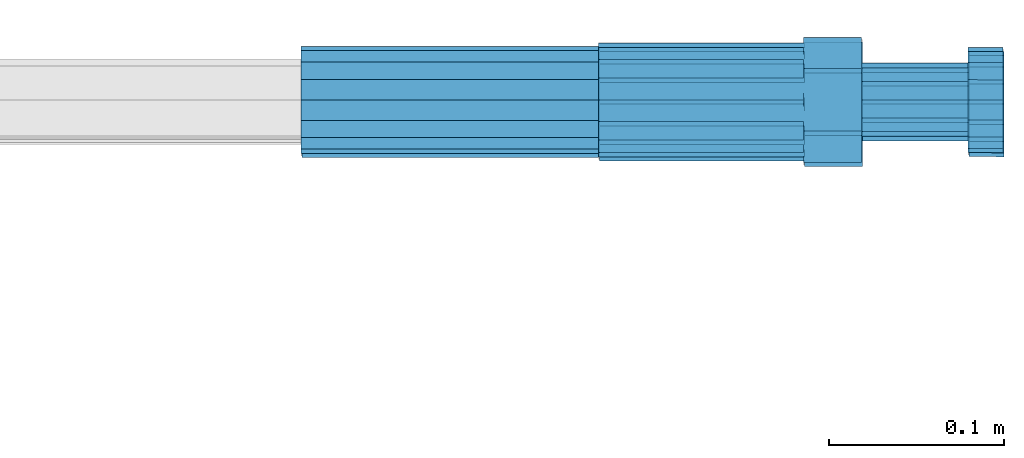
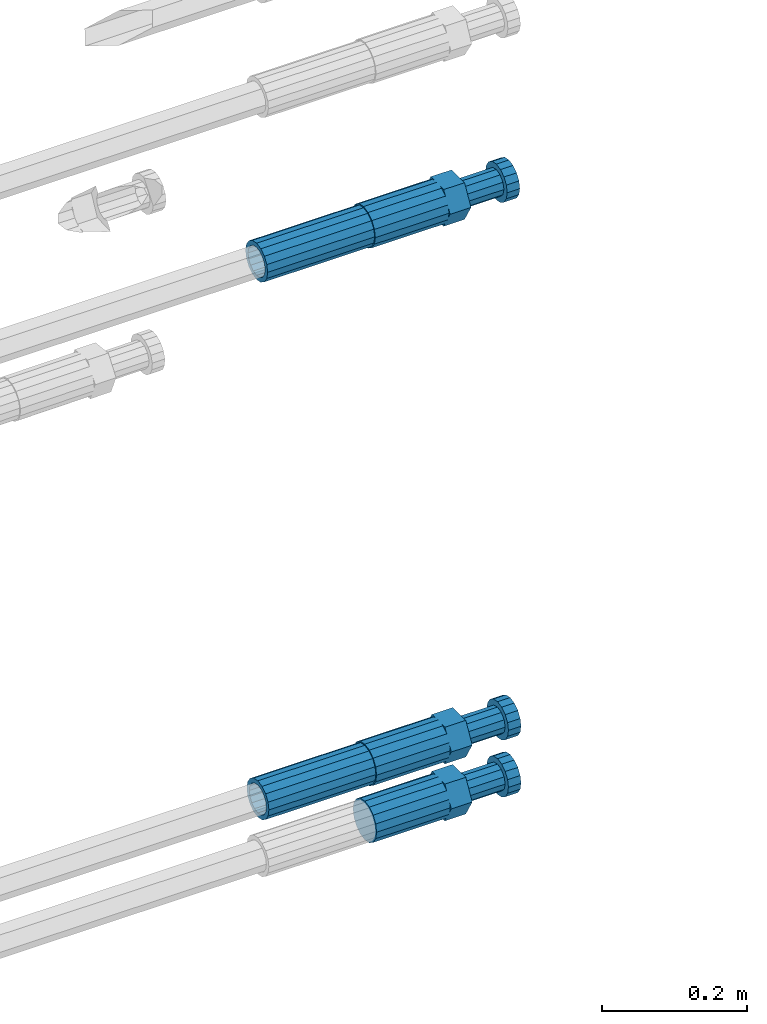
# One storey, part 113 of 177: 5 beams.
"""IFC2X3 building model written with IfcOpenShell, lengths in millimetres."""

from ifc_helpers import new_model, si_unit, frame, origin_with_axes, place, context, subcontext, project, spatial, faceted_brep, material, type_object, element, save


model = new_model("IFC2X3")

# Units and contexts
model_context_1 = context("Model", 3, precision=1e-05, world=origin_with_axes())
model_context_2 = context("Model", 3, precision=1e-05, world=origin_with_axes())
body_context = subcontext(model_context_2, "Body", "Model", "MODEL_VIEW")
ifc_project = project(units=[si_unit("LENGTHUNIT", "METRE", prefix="MILLI"), si_unit("AREAUNIT", "SQUARE_METRE"), si_unit("VOLUMEUNIT", "CUBIC_METRE"), si_unit("MASSUNIT", "GRAM", prefix="KILO"), si_unit("TIMEUNIT", "SECOND"), si_unit("PLANEANGLEUNIT", "RADIAN"), si_unit("SOLIDANGLEUNIT", "STERADIAN"), si_unit("THERMODYNAMICTEMPERATUREUNIT", "DEGREE_CELSIUS"), si_unit("LUMINOUSINTENSITYUNIT", "LUMEN")], contexts=[model_context_1])

# Site, building, storey
site_placement = place(None, origin_with_axes())
site = spatial("IfcSite", under=ifc_project, at=site_placement, CompositionType="ELEMENT")
building_placement = place(site_placement, origin_with_axes())
building = spatial("IfcBuilding", under=site, at=building_placement, Name="Undefined", CompositionType="ELEMENT")
storey_placement = place(building_placement, origin_with_axes())
storey = spatial("IfcBuildingStorey", under=building, at=storey_placement, Name="Undefined", CompositionType="ELEMENT", Elevation=0.0)

# Beams
ifc_material = material(Name="STEEL/S275")
beam_type_1 = type_object("IfcBeamType", PredefinedType="NOTDEFINED")
beam_1_placement = place(storey_placement, frame((2039349.52037948, 6206397.98588036, 18692.99680043), z_axis=(0.0, 0.0, -1.0), x_axis=(1.0, 0.0, 0.0)))
element("IfcBeam", 1, at=beam_1_placement, inside=storey, type_object=beam_type_1, material=ifc_material, Name="AG40N", context=body_context, shape_type="Brep", body=[
    faceted_brep([(0.0, -23.5000000001164, -9.31322574615479e-10), (0.0, -21.7111690140155, 8.99306066054851), (170.0, -21.7111690140155, 8.99306066054851), (170.0, -23.5, 0.0), (0.0, -16.6170093578839, 16.6170093575493), (170.0, -16.6170093578839, 16.6170093575493), (0.0, -8.99306066057943, 21.7111690137535), (170.0, -8.99306066057943, 21.7111690137535), (0.0, 1.16415321826935e-10, 23.5), (170.0, 0.0, 23.5), (0.0, 8.99306066057943, 21.7111690137535), (170.0, 8.99306066057943, 21.7111690137535), (0.0, 16.6170093578839, 16.6170093575493), (170.0, 16.6170093578839, 16.6170093575493), (0.0, 21.7111690140155, 8.99306066054851), (170.0, 21.7111690140155, 8.99306066054851), (0.0, 23.5000000001164, -9.31322574615479e-10), (170.0, 23.5, 0.0), (0.0, 21.7111690140155, -8.99306066054851), (170.0, 21.7111690140155, -8.99306066054851), (0.0, 16.6170093578839, -16.6170093575493), (170.0, 16.6170093578839, -16.6170093575493), (0.0, 8.99306066057943, -21.7111690137535), (170.0, 8.99306066057943, -21.7111690137535), (0.0, 1.16415321826935e-10, -23.5000000009313), (170.0, 0.0, -23.5), (0.0, -8.99306066057943, -21.7111690137535), (170.0, -8.99306066057943, -21.7111690137535), (0.0, -16.6170093578839, -16.6170093575493), (170.0, -16.6170093578839, -16.6170093575493), (0.0, -21.7111690140155, -8.99306066054851), (170.0, -21.7111690140155, -8.99306066054851), (0.0, -30.5, 0.0), (0.0, -28.1783257415937, -11.6718446873128), (170.0, -28.1783257415937, -11.6718446873128), (170.0, -30.5, 0.0), (0.0, -21.5667568261888, -21.5667568258941), (170.0, -21.5667568261888, -21.5667568258941), (0.0, -11.6718446871346, -28.1783257415518), (170.0, -11.6718446871346, -28.1783257415518), (0.0, 0.0, -30.5), (170.0, 0.0, -30.5), (0.0, 11.6718446871346, -28.1783257415518), (170.0, 11.6718446871346, -28.1783257415518), (0.0, 21.5667568261888, -21.5667568258941), (170.0, 21.5667568261888, -21.5667568258941), (0.0, 28.1783257415937, -11.6718446873128), (170.0, 28.1783257415937, -11.6718446873128), (0.0, 30.5, 0.0), (170.0, 30.5, 0.0), (0.0, 28.1783257415937, 11.6718446873128), (170.0, 28.1783257415937, 11.6718446873128), (0.0, 21.5667568261888, 21.5667568258941), (170.0, 21.5667568261888, 21.5667568258941), (0.0, 11.6718446871346, 28.1783257415518), (170.0, 11.6718446871346, 28.1783257415518), (0.0, 0.0, 30.5), (170.0, 0.0, 30.5), (0.0, -11.6718446871346, 28.1783257415518), (170.0, -11.6718446871346, 28.1783257415518), (0.0, -21.5667568261888, 21.5667568258941), (170.0, -21.5667568261888, 21.5667568258941), (0.0, -28.1783257415937, 11.6718446873128), (170.0, -28.1783257415937, 11.6718446873128)], [[[0, 1, 2, 3]], [[1, 4, 5, 2]], [[4, 6, 7, 5]], [[6, 8, 9, 7]], [[8, 10, 11, 9]], [[10, 12, 13, 11]], [[12, 14, 15, 13]], [[14, 16, 17, 15]], [[16, 18, 19, 17]], [[18, 20, 21, 19]], [[20, 22, 23, 21]], [[22, 24, 25, 23]], [[24, 26, 27, 25]], [[26, 28, 29, 27]], [[28, 30, 31, 29]], [[30, 0, 3, 31]], [[32, 33, 34, 35]], [[33, 36, 37, 34]], [[36, 38, 39, 37]], [[38, 40, 41, 39]], [[40, 42, 43, 41]], [[42, 44, 45, 43]], [[44, 46, 47, 45]], [[46, 48, 49, 47]], [[48, 50, 51, 49]], [[50, 52, 53, 51]], [[52, 54, 55, 53]], [[54, 56, 57, 55]], [[56, 58, 59, 57]], [[58, 60, 61, 59]], [[60, 62, 63, 61]], [[62, 32, 35, 63]], [[37, 39, 41, 43, 45, 47, 49, 51, 53, 55, 57, 59, 61, 63, 35, 34], [5, 7, 9, 11, 13, 15, 17, 19, 21, 23, 25, 27, 29, 31, 3, 2]], [[62, 60, 58, 56, 54, 52, 50, 48, 46, 44, 42, 40, 38, 36, 33, 32], [30, 28, 26, 24, 22, 20, 18, 16, 14, 12, 10, 8, 6, 4, 1, 0]]]),
])
beam_2_placement = place(storey_placement, frame((2039349.02037948, 6206400.48588035, 19594.9868004301), z_axis=(0.0, 0.0, -1.0), x_axis=(1.0, 0.0, 0.0)))
element("IfcBeam", 2, at=beam_2_placement, inside=storey, type_object=beam_type_1, material=ifc_material, Name="AG40N", context=body_context, shape_type="Brep", body=[
    faceted_brep([(0.0, -23.5000000001164, -9.31322574615479e-10), (0.0, -21.7111690140155, 8.99306066054851), (170.0, -21.7111690140155, 8.99306066054851), (170.0, -23.5, 0.0), (0.0, -16.6170093578839, 16.6170093575493), (170.0, -16.6170093578839, 16.6170093575493), (0.0, -8.99306066057943, 21.7111690137535), (170.0, -8.99306066057943, 21.7111690137535), (0.0, 1.16415321826935e-10, 23.5), (170.0, 0.0, 23.5), (0.0, 8.99306066057943, 21.7111690137535), (170.0, 8.99306066057943, 21.7111690137535), (0.0, 16.6170093578839, 16.6170093575493), (170.0, 16.6170093578839, 16.6170093575493), (0.0, 21.7111690140155, 8.99306066054851), (170.0, 21.7111690140155, 8.99306066054851), (0.0, 23.5000000001164, -9.31322574615479e-10), (170.0, 23.5, 0.0), (0.0, 21.7111690140155, -8.99306066054851), (170.0, 21.7111690140155, -8.99306066054851), (0.0, 16.6170093578839, -16.6170093575493), (170.0, 16.6170093578839, -16.6170093575493), (0.0, 8.99306066057943, -21.7111690137535), (170.0, 8.99306066057943, -21.7111690137535), (0.0, 1.16415321826935e-10, -23.5000000009313), (170.0, 0.0, -23.5), (0.0, -8.99306066057943, -21.7111690137535), (170.0, -8.99306066057943, -21.7111690137535), (0.0, -16.6170093578839, -16.6170093575493), (170.0, -16.6170093578839, -16.6170093575493), (0.0, -21.7111690140155, -8.99306066054851), (170.0, -21.7111690140155, -8.99306066054851), (0.0, -30.5, 0.0), (0.0, -28.1783257415937, -11.6718446873128), (170.0, -28.1783257415937, -11.6718446873128), (170.0, -30.5, 0.0), (0.0, -21.5667568261888, -21.5667568258941), (170.0, -21.5667568261888, -21.5667568258941), (0.0, -11.6718446871346, -28.1783257415518), (170.0, -11.6718446871346, -28.1783257415518), (0.0, 0.0, -30.5), (170.0, 0.0, -30.5), (0.0, 11.6718446871346, -28.1783257415518), (170.0, 11.6718446871346, -28.1783257415518), (0.0, 21.5667568261888, -21.5667568258941), (170.0, 21.5667568261888, -21.5667568258941), (0.0, 28.1783257415937, -11.6718446873128), (170.0, 28.1783257415937, -11.6718446873128), (0.0, 30.5, 0.0), (170.0, 30.5, 0.0), (0.0, 28.1783257415937, 11.6718446873128), (170.0, 28.1783257415937, 11.6718446873128), (0.0, 21.5667568261888, 21.5667568258941), (170.0, 21.5667568261888, 21.5667568258941), (0.0, 11.6718446871346, 28.1783257415518), (170.0, 11.6718446871346, 28.1783257415518), (0.0, 0.0, 30.5), (170.0, 0.0, 30.5), (0.0, -11.6718446871346, 28.1783257415518), (170.0, -11.6718446871346, 28.1783257415518), (0.0, -21.5667568261888, 21.5667568258941), (170.0, -21.5667568261888, 21.5667568258941), (0.0, -28.1783257415937, 11.6718446873128), (170.0, -28.1783257415937, 11.6718446873128)], [[[0, 1, 2, 3]], [[1, 4, 5, 2]], [[4, 6, 7, 5]], [[6, 8, 9, 7]], [[8, 10, 11, 9]], [[10, 12, 13, 11]], [[12, 14, 15, 13]], [[14, 16, 17, 15]], [[16, 18, 19, 17]], [[18, 20, 21, 19]], [[20, 22, 23, 21]], [[22, 24, 25, 23]], [[24, 26, 27, 25]], [[26, 28, 29, 27]], [[28, 30, 31, 29]], [[30, 0, 3, 31]], [[32, 33, 34, 35]], [[33, 36, 37, 34]], [[36, 38, 39, 37]], [[38, 40, 41, 39]], [[40, 42, 43, 41]], [[42, 44, 45, 43]], [[44, 46, 47, 45]], [[46, 48, 49, 47]], [[48, 50, 51, 49]], [[50, 52, 53, 51]], [[52, 54, 55, 53]], [[54, 56, 57, 55]], [[56, 58, 59, 57]], [[58, 60, 61, 59]], [[60, 62, 63, 61]], [[62, 32, 35, 63]], [[37, 39, 41, 43, 45, 47, 49, 51, 53, 55, 57, 59, 61, 63, 35, 34], [5, 7, 9, 11, 13, 15, 17, 19, 21, 23, 25, 27, 29, 31, 3, 2]], [[62, 60, 58, 56, 54, 52, 50, 48, 46, 44, 42, 40, 38, 36, 33, 32], [30, 28, 26, 24, 22, 20, 18, 16, 14, 12, 10, 8, 6, 4, 1, 0]]]),
])
beam_type_2 = type_object("IfcBeamType", Name="ROD65", PredefinedType="NOTDEFINED")
beam_3_placement = place(storey_placement, frame((2039519.52037948, 6206397.98588036, 18597.2968004168), z_axis=(0.0, 0.0, -1.0), x_axis=(1.0, 0.0, 0.0)))
element("IfcBeam", 3, at=beam_3_placement, inside=storey, type_object=beam_type_2, material=ifc_material, Name="AGB40", ObjectType="ROD65", context=body_context, shape_type="Brep", body=[
    faceted_brep([(117.0, 8.17543110251427, 30.873805644922), (117.0, 17.8250000001863, 30.873805644922), (117.0, 22.0056958701462, 23.6326279877685), (117.0, 12.4372115517035, 30.0260848065373), (117.0, -17.8250000001863, 30.873805644922), (150.200000000186, -17.8250000001863, 30.873805644922), (150.200000000186, 17.8250000001863, 30.873805644922), (117.0, -8.17543110251427, 30.873805644922), (117.0, -12.4372115517035, 30.0260848065373), (117.0, -22.0056958701462, 23.6326279877685), (117.0, -35.6500000003725, 0.0), (150.200000000186, -35.6500000003725, 0.0), (117.0, -30.8443150008097, 8.32369058486074), (117.0, -32.5, 0.0), (117.0, -30.8443150008097, -8.32369058462791), (117.0, -17.8250000001863, -30.873805644922), (150.200000000186, -17.8250000001863, -30.873805644922), (117.0, -22.0056958701462, -23.6326279877685), (117.0, -12.4372115517035, -30.0260848065373), (117.0, -8.17543110251427, -30.873805644922), (117.0, 17.8250000001863, -30.873805644922), (150.200000000186, 17.8250000001863, -30.873805644922), (117.0, 8.17543110251427, -30.873805644922), (117.0, 22.0056958701462, -23.6326279877685), (117.0, 12.4372115517035, -30.0260848065373), (117.0, 35.6500000003725, 0.0), (150.200000000186, 35.6500000003725, 0.0), (117.0, 30.8443150008097, -8.32369058486074), (117.0, 30.8443150008097, 8.32369058462791), (117.0, 32.5, 0.0), (0.0, -22.9809703892097, 22.9809703885621), (0.0, -30.0260848058388, 12.4372115518636), (117.0, -30.0260848067701, 12.4372115519363), (117.0, -22.9809703882784, 22.9809703885112), (-2.3283064365387e-10, 22.9809703892097, -22.9809703885639), (-4.65661287307739e-10, 30.0260848077014, -12.4372115518672), (117.0, 30.0260848067701, -12.4372115519363), (117.0, 22.9809703882784, -22.9809703885112), (-2.3283064365387e-10, -30.0260848067701, -12.4372115518672), (-2.3283064365387e-10, -22.9809703892097, -22.9809703885621), (117.0, -22.9809703882784, -22.9809703885112), (117.0, -30.0260848067701, -12.4372115519363), (-2.3283064365387e-10, -12.4372115507722, 30.0260848066137), (-2.3283064365387e-10, 9.31322574615479e-10, 32.4999999999982), (-2.3283064365387e-10, 12.4372115526348, 30.0260848066137), (0.0, 22.9809703892097, 22.9809703885621), (-2.3283064365387e-10, 30.0260848077014, 12.4372115518636), (-2.3283064365387e-10, 32.5, 0.0), (-2.3283064365387e-10, 12.4372115526348, -30.0260848066173), (-2.3283064365387e-10, 9.31322574615479e-10, -32.5), (-2.3283064365387e-10, -12.4372115517035, -30.0260848066173), (-4.65661287307739e-10, -32.4999999990687, -1.81898940354586e-12), (117.0, 22.9809703882784, 22.9809703885112), (117.0, 30.0260848067701, 12.4372115519363), (117.0, 0.0, -32.5), (117.0, 0.0, 32.5), (150.200000000186, 10.5, -18.1865334794857), (150.200000000186, 0.0, -21.0), (150.200000000186, -10.5, -18.1865334794857), (150.200000000186, -18.18653347902, -10.5), (150.200000000186, -21.0, 0.0), (150.200000000186, -18.18653347902, 10.5), (150.200000000186, -10.5, 18.1865334794857), (150.200000000186, 0.0, 21.0), (150.200000000186, 10.5, 18.1865334794857), (150.200000000186, 18.18653347902, 10.5), (150.200000000186, 21.0, 0.0), (150.200000000186, 18.18653347902, -10.5), (210.980000000447, -18.18653347902, 10.5), (210.980000000447, -21.0, 0.0), (210.980000000447, -10.5, 18.1865334794857), (210.980000000447, 0.0, 21.0), (210.980000000447, 10.5, 18.1865334794857), (210.980000000447, 18.18653347902, 10.5), (210.980000000447, 21.0, 0.0), (210.980000000447, 18.18653347902, -10.5), (210.980000000447, 10.5, -18.1865334794857), (210.980000000447, 0.0, -21.0), (210.980000000447, -10.5, -18.1865334794857), (210.980000000447, -18.18653347902, -10.5), (211.001368442696, -27.7269937992096, -11.491116326768), (211.003082550167, -21.2238094303757, -21.223815418547), (231.002518367059, -21.2131944671273, -21.2132004550658), (231.000804259587, -27.7163788359612, -11.4805013632867), (211.001368440451, -11.4911085031927, -27.7269970395137), (231.000804257343, -11.4804935399443, -27.7163820760325), (210.996487071217, -0.0106065049767494, -30.0106107392348), (230.995922888109, 8.45827162265778e-06, -29.9999957757536), (210.989181586672, 11.46989420522, -27.7269970329944), (230.988617403564, 11.4805091684684, -27.7163820695132), (210.980564180623, 21.2025914648548, -21.2238154064398), (230.979999997515, 21.2132064281031, -21.2132004429586), (210.971946775022, 27.7057703435421, -11.4911163107026), (230.971382591913, 27.7163853067905, -11.4805013472214), (210.96464129175, 29.9893808094785, -0.0106149562634528), (230.964077108642, 29.9999957727268, 7.21774995326996e-09), (210.959759924415, 27.7057638689876, 11.4698863970116), (230.959195741307, 27.7163788322359, 11.4805013604928), (210.958045816944, 21.2025795001537, 21.2025854887906), (230.957481633835, 21.213194463402, 21.2132004522718), (210.95975992666, 11.4698785729706, 27.7057671097573), (230.959195743551, 11.480493536219, 27.7163820732385), (210.964641295894, -0.010623425245285, 29.9893808094785), (230.964077112785, -8.46199691295624e-06, 29.9999957729597), (210.971946780439, -11.4911241354421, 27.705767103238), (230.97138259733, -11.4805091721937, 27.7163820667192), (210.980564186488, -21.2238213950768, 21.2025854766835), (230.980000003379, -21.2132064318284, 21.2132004401647), (210.989181592089, -27.7270002737641, 11.4698863809463), (230.988617408981, -27.7163853105158, 11.4805013444275), (210.996487075361, -30.0106107397005, -0.0106149734929204), (230.995922892253, -29.9999957764521, -1.00117176771164e-08)], [[[0, 1, 2, 3]], [[4, 5, 6, 1, 0, 7]], [[4, 7, 8, 9]], [[10, 11, 5, 4, 9, 12]], [[10, 12, 13, 14]], [[15, 16, 11, 10, 14, 17]], [[15, 17, 18, 19]], [[20, 21, 16, 15, 19, 22]], [[23, 20, 22, 24]], [[25, 26, 21, 20, 23, 27]], [[28, 25, 27, 29]], [[30, 31, 32, 33]], [[34, 35, 36, 37]], [[38, 39, 40, 41]], [[31, 30, 42, 43, 44, 45, 46, 47, 35, 34, 48, 49, 50, 39, 38, 51]], [[46, 45, 52, 53]], [[29, 47, 46, 53, 28]], [[27, 36, 35, 47, 29]], [[23, 37, 36, 27]], [[24, 48, 34, 37, 23]], [[22, 54, 49, 48, 24]], [[19, 54, 22]], [[18, 50, 49, 54, 19]], [[17, 40, 39, 50, 18]], [[14, 41, 40, 17]], [[13, 51, 38, 41, 14]], [[12, 32, 31, 51, 13]], [[9, 33, 32, 12]], [[8, 42, 30, 33, 9]], [[7, 55, 43, 42, 8]], [[0, 55, 7]], [[3, 44, 43, 55, 0]], [[2, 52, 45, 44, 3]], [[28, 53, 52, 2]], [[1, 6, 26, 25, 28, 2]], [[5, 11, 16, 21, 26, 6], [56, 57, 58, 59, 60, 61, 62, 63, 64, 65, 66, 67]], [[68, 61, 60, 69]], [[70, 62, 61, 68]], [[71, 63, 62, 70]], [[72, 64, 63, 71]], [[73, 65, 64, 72]], [[74, 66, 65, 73]], [[75, 67, 66, 74]], [[76, 56, 67, 75]], [[77, 57, 56, 76]], [[78, 58, 57, 77]], [[79, 59, 58, 78]], [[69, 60, 59, 79]], [[80, 81, 82, 83]], [[81, 84, 85, 82]], [[84, 86, 87, 85]], [[86, 88, 89, 87]], [[88, 90, 91, 89]], [[90, 92, 93, 91]], [[92, 94, 95, 93]], [[94, 96, 97, 95]], [[96, 98, 99, 97]], [[98, 100, 101, 99]], [[100, 102, 103, 101]], [[102, 104, 105, 103]], [[104, 106, 107, 105]], [[106, 108, 109, 107]], [[108, 110, 111, 109]], [[82, 85, 87, 89, 91, 93, 95, 97, 99, 101, 103, 105, 107, 109, 111, 83]], [[110, 80, 83, 111]], [[108, 106, 104, 102, 100, 98, 96, 94, 92, 90, 88, 86, 84, 81, 80, 110], [75, 74, 73, 72, 71, 70, 68, 69, 79, 78, 77, 76]]]),
])
beam_4_placement = place(storey_placement, frame((2039519.52037948, 6206397.98588036, 18692.9968004298), z_axis=(0.0, 0.0, -1.0), x_axis=(1.0, 0.0, 0.0)))
element("IfcBeam", 4, at=beam_4_placement, inside=storey, type_object=beam_type_2, material=ifc_material, Name="AGB40", ObjectType="ROD65", context=body_context, shape_type="Brep", body=[
    faceted_brep([(117.0, 8.17543110251427, 30.873805644922), (117.0, 17.8250000001863, 30.873805644922), (117.0, 22.0056958701462, 23.6326279877685), (117.0, 12.4372115517035, 30.0260848065373), (117.0, -17.8250000001863, 30.873805644922), (150.200000000186, -17.8250000001863, 30.873805644922), (150.200000000186, 17.8250000001863, 30.873805644922), (117.0, -8.17543110251427, 30.873805644922), (117.0, -12.4372115517035, 30.0260848065373), (117.0, -22.0056958701462, 23.6326279877685), (117.0, -35.6500000003725, 0.0), (150.200000000186, -35.6500000003725, 0.0), (117.0, -30.8443150008097, 8.32369058486074), (117.0, -32.5, 0.0), (117.0, -30.8443150008097, -8.32369058462791), (117.0, -17.8250000001863, -30.873805644922), (150.200000000186, -17.8250000001863, -30.873805644922), (117.0, -22.0056958701462, -23.6326279877685), (117.0, -12.4372115517035, -30.0260848065373), (117.0, -8.17543110251427, -30.873805644922), (117.0, 17.8250000001863, -30.873805644922), (150.200000000186, 17.8250000001863, -30.873805644922), (117.0, 8.17543110251427, -30.873805644922), (117.0, 22.0056958701462, -23.6326279877685), (117.0, 12.4372115517035, -30.0260848065373), (117.0, 35.6500000003725, 0.0), (150.200000000186, 35.6500000003725, 0.0), (117.0, 30.8443150008097, -8.32369058486074), (117.0, 30.8443150008097, 8.32369058462791), (117.0, 32.5, 0.0), (0.0, -22.9809703892097, 22.9809703885621), (0.0, -30.0260848058388, 12.4372115518636), (117.0, -30.0260848067701, 12.4372115519363), (117.0, -22.9809703882784, 22.9809703885112), (-2.3283064365387e-10, 22.9809703892097, -22.9809703885639), (-4.65661287307739e-10, 30.0260848077014, -12.4372115518672), (117.0, 30.0260848067701, -12.4372115519363), (117.0, 22.9809703882784, -22.9809703885112), (-2.3283064365387e-10, -30.0260848067701, -12.4372115518672), (-2.3283064365387e-10, -22.9809703892097, -22.9809703885621), (117.0, -22.9809703882784, -22.9809703885112), (117.0, -30.0260848067701, -12.4372115519363), (-2.3283064365387e-10, -12.4372115507722, 30.0260848066137), (-2.3283064365387e-10, 9.31322574615479e-10, 32.4999999999982), (-2.3283064365387e-10, 12.4372115526348, 30.0260848066137), (0.0, 22.9809703892097, 22.9809703885621), (-2.3283064365387e-10, 30.0260848077014, 12.4372115518636), (-2.3283064365387e-10, 32.5, 0.0), (-2.3283064365387e-10, 12.4372115526348, -30.0260848066173), (-2.3283064365387e-10, 9.31322574615479e-10, -32.5), (-2.3283064365387e-10, -12.4372115517035, -30.0260848066173), (-4.65661287307739e-10, -32.4999999990687, -1.81898940354586e-12), (117.0, 22.9809703882784, 22.9809703885112), (117.0, 30.0260848067701, 12.4372115519363), (117.0, 0.0, -32.5), (117.0, 0.0, 32.5), (150.200000000186, 10.5, -18.1865334794857), (150.200000000186, 0.0, -21.0), (150.200000000186, -10.5, -18.1865334794857), (150.200000000186, -18.18653347902, -10.5), (150.200000000186, -21.0, 0.0), (150.200000000186, -18.18653347902, 10.5), (150.200000000186, -10.5, 18.1865334794857), (150.200000000186, 0.0, 21.0), (150.200000000186, 10.5, 18.1865334794857), (150.200000000186, 18.18653347902, 10.5), (150.200000000186, 21.0, 0.0), (150.200000000186, 18.18653347902, -10.5), (210.980000000447, -18.18653347902, 10.5), (210.980000000447, -21.0, 0.0), (210.980000000447, -10.5, 18.1865334794857), (210.980000000447, 0.0, 21.0), (210.980000000447, 10.5, 18.1865334794857), (210.980000000447, 18.18653347902, 10.5), (210.980000000447, 21.0, 0.0), (210.980000000447, 18.18653347902, -10.5), (210.980000000447, 10.5, -18.1865334794857), (210.980000000447, 0.0, -21.0), (210.980000000447, -10.5, -18.1865334794857), (210.980000000447, -18.18653347902, -10.5), (211.001368442696, -27.7269937992096, -11.491116326768), (211.003082550167, -21.2238094303757, -21.223815418547), (231.002518367059, -21.2131944671273, -21.2132004550658), (231.000804259587, -27.7163788359612, -11.4805013632867), (211.001368440451, -11.4911085031927, -27.7269970395137), (231.000804257343, -11.4804935399443, -27.7163820760325), (210.996487071217, -0.0106065049767494, -30.0106107392348), (230.995922888109, 8.45827162265778e-06, -29.9999957757536), (210.989181586672, 11.46989420522, -27.7269970329944), (230.988617403564, 11.4805091684684, -27.7163820695132), (210.980564180623, 21.2025914648548, -21.2238154064398), (230.979999997515, 21.2132064281031, -21.2132004429586), (210.971946775022, 27.7057703435421, -11.4911163107026), (230.971382591913, 27.7163853067905, -11.4805013472214), (210.96464129175, 29.9893808094785, -0.0106149562634528), (230.964077108642, 29.9999957727268, 7.21774995326996e-09), (210.959759924415, 27.7057638689876, 11.4698863970116), (230.959195741307, 27.7163788322359, 11.4805013604928), (210.958045816944, 21.2025795001537, 21.2025854887906), (230.957481633835, 21.213194463402, 21.2132004522718), (210.95975992666, 11.4698785729706, 27.7057671097573), (230.959195743551, 11.480493536219, 27.7163820732385), (210.964641295894, -0.010623425245285, 29.9893808094785), (230.964077112785, -8.46199691295624e-06, 29.9999957729597), (210.971946780439, -11.4911241354421, 27.705767103238), (230.97138259733, -11.4805091721937, 27.7163820667192), (210.980564186488, -21.2238213950768, 21.2025854766835), (230.980000003379, -21.2132064318284, 21.2132004401647), (210.989181592089, -27.7270002737641, 11.4698863809463), (230.988617408981, -27.7163853105158, 11.4805013444275), (210.996487075361, -30.0106107397005, -0.0106149734929204), (230.995922892253, -29.9999957764521, -1.00117176771164e-08)], [[[0, 1, 2, 3]], [[4, 5, 6, 1, 0, 7]], [[4, 7, 8, 9]], [[10, 11, 5, 4, 9, 12]], [[10, 12, 13, 14]], [[15, 16, 11, 10, 14, 17]], [[15, 17, 18, 19]], [[20, 21, 16, 15, 19, 22]], [[23, 20, 22, 24]], [[25, 26, 21, 20, 23, 27]], [[28, 25, 27, 29]], [[30, 31, 32, 33]], [[34, 35, 36, 37]], [[38, 39, 40, 41]], [[31, 30, 42, 43, 44, 45, 46, 47, 35, 34, 48, 49, 50, 39, 38, 51]], [[46, 45, 52, 53]], [[29, 47, 46, 53, 28]], [[27, 36, 35, 47, 29]], [[23, 37, 36, 27]], [[24, 48, 34, 37, 23]], [[22, 54, 49, 48, 24]], [[19, 54, 22]], [[18, 50, 49, 54, 19]], [[17, 40, 39, 50, 18]], [[14, 41, 40, 17]], [[13, 51, 38, 41, 14]], [[12, 32, 31, 51, 13]], [[9, 33, 32, 12]], [[8, 42, 30, 33, 9]], [[7, 55, 43, 42, 8]], [[0, 55, 7]], [[3, 44, 43, 55, 0]], [[2, 52, 45, 44, 3]], [[28, 53, 52, 2]], [[1, 6, 26, 25, 28, 2]], [[5, 11, 16, 21, 26, 6], [56, 57, 58, 59, 60, 61, 62, 63, 64, 65, 66, 67]], [[68, 61, 60, 69]], [[70, 62, 61, 68]], [[71, 63, 62, 70]], [[72, 64, 63, 71]], [[73, 65, 64, 72]], [[74, 66, 65, 73]], [[75, 67, 66, 74]], [[76, 56, 67, 75]], [[77, 57, 56, 76]], [[78, 58, 57, 77]], [[79, 59, 58, 78]], [[69, 60, 59, 79]], [[80, 81, 82, 83]], [[81, 84, 85, 82]], [[84, 86, 87, 85]], [[86, 88, 89, 87]], [[88, 90, 91, 89]], [[90, 92, 93, 91]], [[92, 94, 95, 93]], [[94, 96, 97, 95]], [[96, 98, 99, 97]], [[98, 100, 101, 99]], [[100, 102, 103, 101]], [[102, 104, 105, 103]], [[104, 106, 107, 105]], [[106, 108, 109, 107]], [[108, 110, 111, 109]], [[82, 85, 87, 89, 91, 93, 95, 97, 99, 101, 103, 105, 107, 109, 111, 83]], [[110, 80, 83, 111]], [[108, 106, 104, 102, 100, 98, 96, 94, 92, 90, 88, 86, 84, 81, 80, 110], [75, 74, 73, 72, 71, 70, 68, 69, 79, 78, 77, 76]]]),
])
beam_5_placement = place(storey_placement, frame((2039519.02037948, 6206400.48588035, 19594.9868004299), z_axis=(0.0, 0.0, -1.0), x_axis=(1.0, 0.0, 0.0)))
element("IfcBeam", 5, at=beam_5_placement, inside=storey, type_object=beam_type_2, material=ifc_material, Name="AGB40", ObjectType="ROD65", context=body_context, shape_type="Brep", body=[
    faceted_brep([(117.0, 8.17543110251427, 30.873805644922), (117.0, 17.8250000001863, 30.873805644922), (117.0, 22.0056958701462, 23.6326279877685), (117.0, 12.4372115517035, 30.0260848065373), (117.0, -17.8250000001863, 30.873805644922), (150.200000000186, -17.8250000001863, 30.873805644922), (150.200000000186, 17.8250000001863, 30.873805644922), (117.0, -8.17543110251427, 30.873805644922), (117.0, -12.4372115517035, 30.0260848065373), (117.0, -22.0056958701462, 23.6326279877685), (117.0, -35.6500000003725, 0.0), (150.200000000186, -35.6500000003725, 0.0), (117.0, -30.8443150008097, 8.32369058486074), (117.0, -32.5, 0.0), (117.0, -30.8443150008097, -8.32369058462791), (117.0, -17.8250000001863, -30.873805644922), (150.200000000186, -17.8250000001863, -30.873805644922), (117.0, -22.0056958701462, -23.6326279877685), (117.0, -12.4372115517035, -30.0260848065373), (117.0, -8.17543110251427, -30.873805644922), (117.0, 17.8250000001863, -30.873805644922), (150.200000000186, 17.8250000001863, -30.873805644922), (117.0, 8.17543110251427, -30.873805644922), (117.0, 22.0056958701462, -23.6326279877685), (117.0, 12.4372115517035, -30.0260848065373), (117.0, 35.6500000003725, 0.0), (150.200000000186, 35.6500000003725, 0.0), (117.0, 30.8443150008097, -8.32369058486074), (117.0, 30.8443150008097, 8.32369058462791), (117.0, 32.5, 0.0), (0.0, -22.9809703892097, 22.9809703885621), (0.0, -30.0260848058388, 12.4372115518636), (117.0, -30.0260848067701, 12.4372115519363), (117.0, -22.9809703882784, 22.9809703885112), (-2.3283064365387e-10, 22.9809703892097, -22.9809703885639), (-4.65661287307739e-10, 30.0260848077014, -12.4372115518672), (117.0, 30.0260848067701, -12.4372115519363), (117.0, 22.9809703882784, -22.9809703885112), (-2.3283064365387e-10, -30.0260848067701, -12.4372115518672), (-2.3283064365387e-10, -22.9809703892097, -22.9809703885621), (117.0, -22.9809703882784, -22.9809703885112), (117.0, -30.0260848067701, -12.4372115519363), (-2.3283064365387e-10, -12.4372115507722, 30.0260848066137), (-2.3283064365387e-10, 9.31322574615479e-10, 32.4999999999982), (-2.3283064365387e-10, 12.4372115526348, 30.0260848066137), (0.0, 22.9809703892097, 22.9809703885621), (-2.3283064365387e-10, 30.0260848077014, 12.4372115518636), (-2.3283064365387e-10, 32.5, 0.0), (-2.3283064365387e-10, 12.4372115526348, -30.0260848066173), (-2.3283064365387e-10, 9.31322574615479e-10, -32.5), (-2.3283064365387e-10, -12.4372115517035, -30.0260848066173), (-4.65661287307739e-10, -32.4999999990687, -1.81898940354586e-12), (117.0, 22.9809703882784, 22.9809703885112), (117.0, 30.0260848067701, 12.4372115519363), (117.0, 0.0, -32.5), (117.0, 0.0, 32.5), (150.200000000186, 10.5, -18.1865334794857), (150.200000000186, 0.0, -21.0), (150.200000000186, -10.5, -18.1865334794857), (150.200000000186, -18.18653347902, -10.5), (150.200000000186, -21.0, 0.0), (150.200000000186, -18.18653347902, 10.5), (150.200000000186, -10.5, 18.1865334794857), (150.200000000186, 0.0, 21.0), (150.200000000186, 10.5, 18.1865334794857), (150.200000000186, 18.18653347902, 10.5), (150.200000000186, 21.0, 0.0), (150.200000000186, 18.18653347902, -10.5), (210.980000000447, -18.18653347902, 10.5), (210.980000000447, -21.0, 0.0), (210.980000000447, -10.5, 18.1865334794857), (210.980000000447, 0.0, 21.0), (210.980000000447, 10.5, 18.1865334794857), (210.980000000447, 18.18653347902, 10.5), (210.980000000447, 21.0, 0.0), (210.980000000447, 18.18653347902, -10.5), (210.980000000447, 10.5, -18.1865334794857), (210.980000000447, 0.0, -21.0), (210.980000000447, -10.5, -18.1865334794857), (210.980000000447, -18.18653347902, -10.5), (211.001368442696, -27.7269937992096, -11.491116326768), (211.003082550167, -21.2238094303757, -21.223815418547), (231.002518367059, -21.2131944671273, -21.2132004550658), (231.000804259587, -27.7163788359612, -11.4805013632867), (211.001368440451, -11.4911085031927, -27.7269970395137), (231.000804257343, -11.4804935399443, -27.7163820760325), (210.996487071217, -0.0106065049767494, -30.0106107392348), (230.995922888109, 8.45827162265778e-06, -29.9999957757536), (210.989181586672, 11.46989420522, -27.7269970329944), (230.988617403564, 11.4805091684684, -27.7163820695132), (210.980564180623, 21.2025914648548, -21.2238154064398), (230.979999997515, 21.2132064281031, -21.2132004429586), (210.971946775022, 27.7057703435421, -11.4911163107026), (230.971382591913, 27.7163853067905, -11.4805013472214), (210.96464129175, 29.9893808094785, -0.0106149562634528), (230.964077108642, 29.9999957727268, 7.21774995326996e-09), (210.959759924415, 27.7057638689876, 11.4698863970116), (230.959195741307, 27.7163788322359, 11.4805013604928), (210.958045816944, 21.2025795001537, 21.2025854887906), (230.957481633835, 21.213194463402, 21.2132004522718), (210.95975992666, 11.4698785729706, 27.7057671097573), (230.959195743551, 11.480493536219, 27.7163820732385), (210.964641295894, -0.010623425245285, 29.9893808094785), (230.964077112785, -8.46199691295624e-06, 29.9999957729597), (210.971946780439, -11.4911241354421, 27.705767103238), (230.97138259733, -11.4805091721937, 27.7163820667192), (210.980564186488, -21.2238213950768, 21.2025854766835), (230.980000003379, -21.2132064318284, 21.2132004401647), (210.989181592089, -27.7270002737641, 11.4698863809463), (230.988617408981, -27.7163853105158, 11.4805013444275), (210.996487075361, -30.0106107397005, -0.0106149734929204), (230.995922892253, -29.9999957764521, -1.00117176771164e-08)], [[[0, 1, 2, 3]], [[4, 5, 6, 1, 0, 7]], [[4, 7, 8, 9]], [[10, 11, 5, 4, 9, 12]], [[10, 12, 13, 14]], [[15, 16, 11, 10, 14, 17]], [[15, 17, 18, 19]], [[20, 21, 16, 15, 19, 22]], [[23, 20, 22, 24]], [[25, 26, 21, 20, 23, 27]], [[28, 25, 27, 29]], [[30, 31, 32, 33]], [[34, 35, 36, 37]], [[38, 39, 40, 41]], [[31, 30, 42, 43, 44, 45, 46, 47, 35, 34, 48, 49, 50, 39, 38, 51]], [[46, 45, 52, 53]], [[29, 47, 46, 53, 28]], [[27, 36, 35, 47, 29]], [[23, 37, 36, 27]], [[24, 48, 34, 37, 23]], [[22, 54, 49, 48, 24]], [[19, 54, 22]], [[18, 50, 49, 54, 19]], [[17, 40, 39, 50, 18]], [[14, 41, 40, 17]], [[13, 51, 38, 41, 14]], [[12, 32, 31, 51, 13]], [[9, 33, 32, 12]], [[8, 42, 30, 33, 9]], [[7, 55, 43, 42, 8]], [[0, 55, 7]], [[3, 44, 43, 55, 0]], [[2, 52, 45, 44, 3]], [[28, 53, 52, 2]], [[1, 6, 26, 25, 28, 2]], [[5, 11, 16, 21, 26, 6], [56, 57, 58, 59, 60, 61, 62, 63, 64, 65, 66, 67]], [[68, 61, 60, 69]], [[70, 62, 61, 68]], [[71, 63, 62, 70]], [[72, 64, 63, 71]], [[73, 65, 64, 72]], [[74, 66, 65, 73]], [[75, 67, 66, 74]], [[76, 56, 67, 75]], [[77, 57, 56, 76]], [[78, 58, 57, 77]], [[79, 59, 58, 78]], [[69, 60, 59, 79]], [[80, 81, 82, 83]], [[81, 84, 85, 82]], [[84, 86, 87, 85]], [[86, 88, 89, 87]], [[88, 90, 91, 89]], [[90, 92, 93, 91]], [[92, 94, 95, 93]], [[94, 96, 97, 95]], [[96, 98, 99, 97]], [[98, 100, 101, 99]], [[100, 102, 103, 101]], [[102, 104, 105, 103]], [[104, 106, 107, 105]], [[106, 108, 109, 107]], [[108, 110, 111, 109]], [[82, 85, 87, 89, 91, 93, 95, 97, 99, 101, 103, 105, 107, 109, 111, 83]], [[110, 80, 83, 111]], [[108, 106, 104, 102, 100, 98, 96, 94, 92, 90, 88, 86, 84, 81, 80, 110], [75, 74, 73, 72, 71, 70, 68, 69, 79, 78, 77, 76]]]),
])

save(model, "model.ifc")
